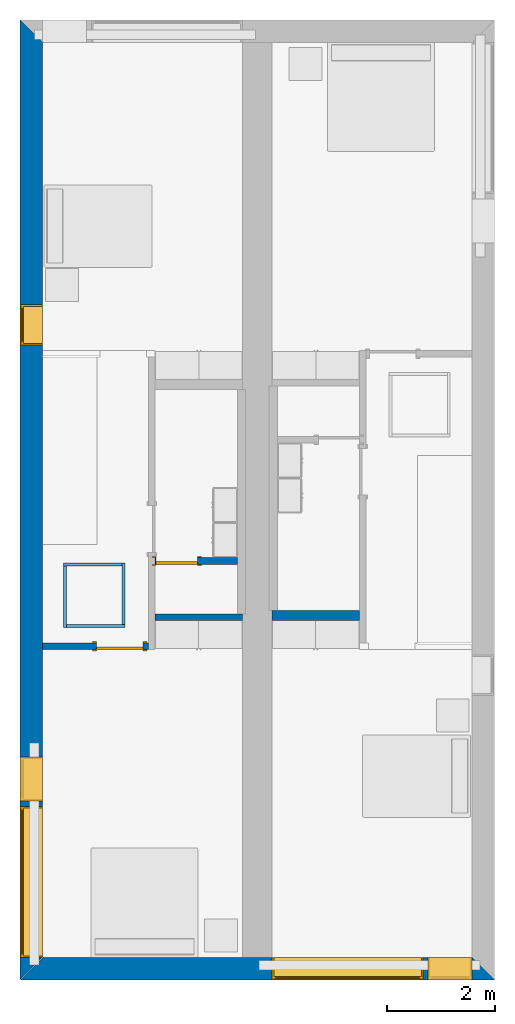
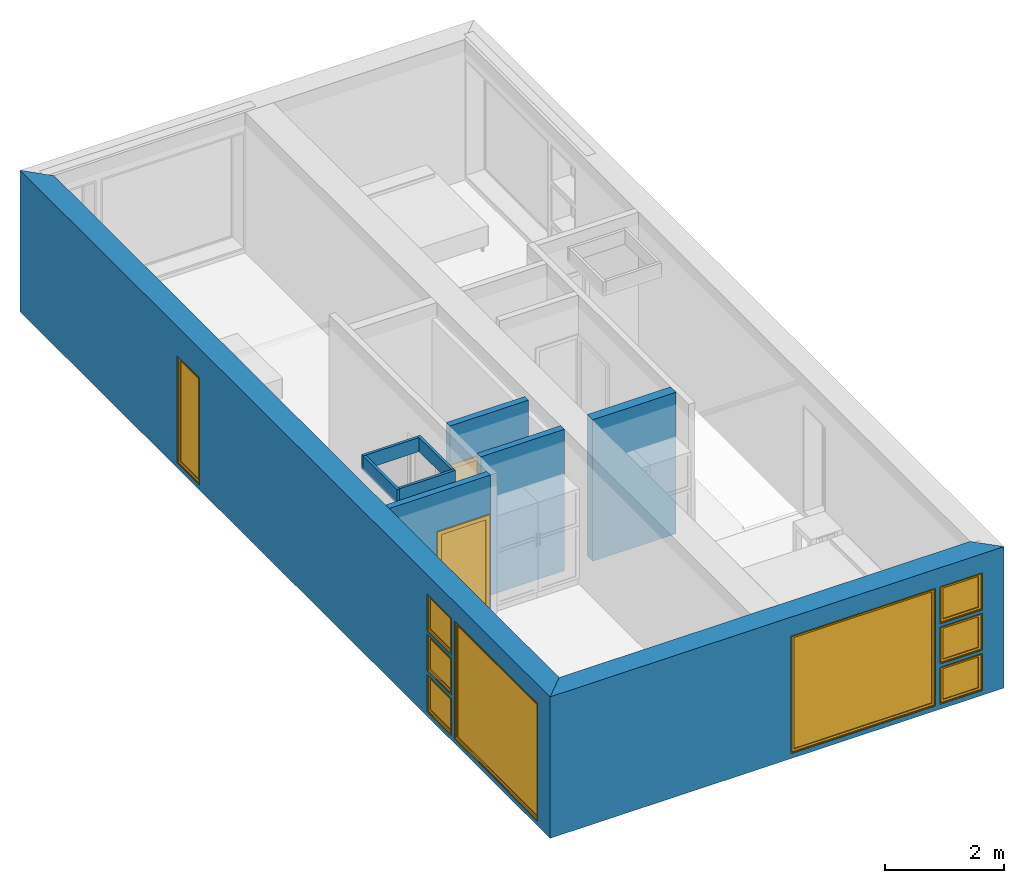
# One storey, part 2 of 16: 10 walls, 9 windows, 2 doors, 11 openings.
"""IFC2X3 building model written with IfcOpenShell, lengths in metres."""

import ifcopenshell
import ifcopenshell.guid

model = None  # the IFC model being written
_history = None  # IfcOwnerHistory: only IFC2X3 demands one
_inside = {}  # id of a spatial element -> (the spatial element, [elements in it])
_under = {}  # id of a project, library or spatial element -> (it, [spatial elements below it])
_declared = {}  # id of a project -> (the project, [libraries it declares])
_typed = {}  # id of a type object -> (the type object, [elements of that type])
_made_of = {}  # id of a material, layer set ... -> (it, [elements and type objects made of it])


def new_model(schema):
    """Start an empty IFC model of exactly this schema.

    Asked for "IFC4X3", IfcOpenShell would pick the latest addendum, in which some entities
    have other attributes; the version numbers below select the first issue.
    IFC2X3 requires an IfcOwnerHistory on every rooted entity: one is made here for all.
    """
    global model, _history
    if schema == "IFC4X3":
        model = ifcopenshell.file(schema_version=(4, 3, 0, 0))
    else:
        model = ifcopenshell.file(schema=schema)
    _inside.clear()
    _under.clear()
    _declared.clear()
    _typed.clear()
    _made_of.clear()
    _history = None
    if model.schema == "IFC2X3":
        org = make("IfcOrganization", Name="unknown")
        user = make(
            "IfcPersonAndOrganization",
            ThePerson=make("IfcPerson", FamilyName="unknown"),
            TheOrganization=org,
        )
        app = make(
            "IfcApplication",
            ApplicationDeveloper=org,
            Version="unknown",
            ApplicationFullName="unknown",
            ApplicationIdentifier="unknown",
        )
        _history = make(
            "IfcOwnerHistory",
            OwningUser=user,
            OwningApplication=app,
            ChangeAction="ADDED",
            CreationDate=0,
        )
    return model


def make(cls, **values):
    """One entity of the class cls with the attributes given. An attribute that is None is left unset."""
    return model.create_entity(
        cls, **{name: value for name, value in values.items() if value is not None}
    )


def entity(cls, *values):
    """Any entity or typed value of the class cls, its attributes in the order of the schema. None: left unset."""
    e = model.create_entity(cls)
    for i, value in enumerate(values):
        if value is not None:
            e[i] = value
    return e


def rooted(cls, **values):
    """An entity with a GlobalId (a new one), such as an element, a storey or a relation."""
    return make(cls, GlobalId=ifcopenshell.guid.new(), OwnerHistory=_history, **values)


def si_unit(unit_type, name, prefix=None):
    """IfcSIUnit, for example si_unit("LENGTHUNIT", "METRE", prefix="MILLI")."""
    return make("IfcSIUnit", UnitType=unit_type, Prefix=prefix, Name=name)


def converted_unit(unit_type, name, factor, base, dimensions=None, offset=None):
    """IfcConversionBasedUnit, such as the inch: factor (a typed value) times the base unit."""
    return make(
        "IfcConversionBasedUnit"
        if offset is None
        else "IfcConversionBasedUnitWithOffset",
        ConversionOffset=offset,
        Dimensions=None
        if dimensions is None
        else entity("IfcDimensionalExponents", *dimensions),
        UnitType=unit_type,
        Name=name,
        ConversionFactor=make(
            "IfcMeasureWithUnit", ValueComponent=factor, UnitComponent=base
        ),
    )


def assignment(units):
    """IfcUnitAssignment: the units of a project."""
    return None if units is None else make("IfcUnitAssignment", Units=units)


def point(xyz):
    """IfcCartesianPoint."""
    return None if xyz is None else make("IfcCartesianPoint", Coordinates=xyz)


def direction(xyz):
    """IfcDirection."""
    return None if xyz is None else make("IfcDirection", DirectionRatios=xyz)


def frame(location, z_axis=None, x_axis=None):
    """IfcAxis2Placement3D, a coordinate frame: its origin and axes. An axis left out is left unset."""
    return make(
        "IfcAxis2Placement3D",
        Location=point(location),
        Axis=direction(z_axis),
        RefDirection=direction(x_axis),
    )


def frame_2d(location, x_axis=None):
    """IfcAxis2Placement2D, a coordinate frame in the plane: its origin and x axis."""
    return make(
        "IfcAxis2Placement2D", Location=point(location), RefDirection=direction(x_axis)
    )


def origin():
    """The frame at (0, 0, 0) with its axes left unset."""
    return frame((0.0, 0.0, 0.0))


def origin_2d_with_axis():
    """The frame at (0, 0) in the plane with the x axis (1, 0) written out."""
    return frame_2d((0.0, 0.0), x_axis=(1.0, 0.0))


def place(relative_to, where):
    """IfcLocalPlacement: puts the frame where relative to a parent placement (None: the world)."""
    return make(
        "IfcLocalPlacement", PlacementRelTo=relative_to, RelativePlacement=where
    )


def context(
    kind, dimensions, precision=None, world=None, true_north=None, identifier=None
):
    """IfcGeometricRepresentationContext, for example the 3D "Model" context."""
    return make(
        "IfcGeometricRepresentationContext",
        ContextIdentifier=identifier,
        ContextType=kind,
        CoordinateSpaceDimension=dimensions,
        Precision=precision,
        WorldCoordinateSystem=world,
        TrueNorth=true_north,
    )


def project(units=None, contexts=None):
    """IfcProject with its units and contexts."""
    return rooted(
        "IfcProject",
        Name="project",
        RepresentationContexts=contexts,
        UnitsInContext=assignment(units),
    )


def spatial(cls, under=None, at=None, **own):
    """A site, building, storey or space (cls), placed at a placement, below another one or the project."""
    s = rooted(cls, ObjectPlacement=at, **own)
    if under is not None:
        _under.setdefault(under.id(), (under, []))[1].append(s)
    return s


def polyline(points):
    """IfcPolyline through the points."""
    return make("IfcPolyline", Points=[point(p) for p in points])


def profile(cls, at=None, kind="AREA", **sizes):
    """A parametric profile (cls). Its sizes go by their IFC names, for example OverallWidth=200.0."""
    return make(cls, ProfileType=kind, Position=at, **sizes)


def rectangle(**sizes):
    """IfcRectangleProfileDef."""
    return profile("IfcRectangleProfileDef", **sizes)


def outline(outer, holes=None, kind="AREA"):
    """IfcArbitraryClosedProfileDef: a profile drawn as a closed curve; with holes, ...WithVoids."""
    if holes is None:
        return make("IfcArbitraryClosedProfileDef", ProfileType=kind, OuterCurve=outer)
    return make(
        "IfcArbitraryProfileDefWithVoids",
        ProfileType=kind,
        OuterCurve=outer,
        InnerCurves=holes,
    )


def extrude(swept, where, along, depth):
    """IfcExtrudedAreaSolid: the profile swept, set in the frame where, extruded along a direction by depth."""
    return make(
        "IfcExtrudedAreaSolid",
        SweptArea=swept,
        Position=where,
        ExtrudedDirection=direction(along),
        Depth=depth,
    )


def shape(context_of_items, identifier, shape_type, items):
    """IfcShapeRepresentation: the items that make up one representation, for example the "Body"."""
    return make(
        "IfcShapeRepresentation",
        ContextOfItems=context_of_items,
        RepresentationIdentifier=identifier,
        RepresentationType=shape_type,
        Items=items,
    )


def source(mapping_origin, context_of_items, identifier, shape_type, items):
    """IfcRepresentationMap: a shape defined once, which mapped items show again and again."""
    return make(
        "IfcRepresentationMap",
        MappingOrigin=mapping_origin,
        MappedRepresentation=shape(context_of_items, identifier, shape_type, items),
    )


def transform(
    local_origin,
    x_axis=None,
    y_axis=None,
    z_axis=None,
    scale=None,
    scale2=None,
    scale3=None,
    uniform=True,
):
    """IfcCartesianTransformationOperator3D, or its non-uniform kind. x_axis, y_axis, z_axis: its Axis1, 2, 3."""
    if uniform:
        return make(
            "IfcCartesianTransformationOperator3D",
            Axis1=direction(x_axis),
            Axis2=direction(y_axis),
            LocalOrigin=point(local_origin),
            Scale=scale,
            Axis3=direction(z_axis),
        )
    return make(
        "IfcCartesianTransformationOperator3DnonUniform",
        Axis1=direction(x_axis),
        Axis2=direction(y_axis),
        LocalOrigin=point(local_origin),
        Scale=scale,
        Axis3=direction(z_axis),
        Scale2=scale2,
        Scale3=scale3,
    )


def mapped(mapping_source, mapping_target):
    """IfcMappedItem: shows the shape of a source again, moved by a transform."""
    return make(
        "IfcMappedItem", MappingSource=mapping_source, MappingTarget=mapping_target
    )


def material(Name=None, Category=None):
    """IfcMaterial."""
    return make("IfcMaterial", Name=Name, Category=Category)


def layer(
    of_material, thickness, ventilated=None, Name=None, Category=None, Priority=None
):
    """IfcMaterialLayer: one layer of a wall or slab, of a material (None: an air gap)."""
    return make(
        "IfcMaterialLayer",
        Material=of_material,
        LayerThickness=thickness,
        IsVentilated=ventilated,
        Name=Name,
        Category=Category,
        Priority=Priority,
    )


def layer_set(layers, Name=None):
    """IfcMaterialLayerSet."""
    return make("IfcMaterialLayerSet", MaterialLayers=layers, LayerSetName=Name)


def layer_usage(for_layer_set, set_direction, sense, offset, extent=None):
    """IfcMaterialLayerSetUsage: how a layer set lies in its element."""
    return make(
        "IfcMaterialLayerSetUsage",
        ForLayerSet=for_layer_set,
        LayerSetDirection=set_direction,
        DirectionSense=sense,
        OffsetFromReferenceLine=offset,
        ReferenceExtent=extent,
    )


def made_of(thing, what):
    """Note that an element or type object is made of a material, layer set ...; save() writes the relation."""
    if what is not None:
        _made_of.setdefault(what.id(), (what, []))[1].append(thing)
    return thing


def type_object(cls, material=None, **own):
    """A type object (cls), such as IfcWallType, which elements share."""
    return made_of(rooted(cls, **own), material)


def type_shapes(of_type, sources):
    """Give a type object the sources (RepresentationMaps) that its elements show as mapped items."""
    of_type.RepresentationMaps = sources


def element(
    cls,
    number,
    at=None,
    inside=None,
    cuts=None,
    type_object=None,
    material=None,
    context=None,
    identifier="Body",
    shape_type=None,
    held_by="IfcProductDefinitionShape",
    body=None,
    shapes=None,
    **own,
):
    """One element of the class cls, such as IfcWall. Its Tag is "e" and its number.

    at: its placement. inside: the storey or other place that contains it. cuts: it is an
    opening in that element (IfcRelVoidsElement). A single representation is given by context,
    identifier, shape_type and body (its items); several are given by shapes. held_by: the class
    of the entity that holds the representations. save() writes the other relations.
    """
    e = rooted(cls, Tag="e%d" % number, ObjectPlacement=at, **own)
    if body is not None:
        shapes = [shape(context, identifier, shape_type, body)]
    if shapes is not None:
        e.Representation = make(held_by, Representations=shapes)
    if inside is not None:
        _inside.setdefault(inside.id(), (inside, []))[1].append(e)
    if cuts is not None:
        rooted(
            "IfcRelVoidsElement", RelatingBuildingElement=cuts, RelatedOpeningElement=e
        )
    if type_object is not None:
        _typed.setdefault(type_object.id(), (type_object, []))[1].append(e)
    return made_of(e, material)


def fill(opening, filler):
    """IfcRelFillsElement: the door or window that sits in an opening."""
    return rooted(
        "IfcRelFillsElement",
        RelatingOpeningElement=opening,
        RelatedBuildingElement=filler,
    )


def aggregate(whole, parts):
    """IfcRelAggregates: a whole, such as a stair, and the parts it consists of."""
    return rooted("IfcRelAggregates", RelatingObject=whole, RelatedObjects=parts)


def save(model, path):
    """Write the relations noted so far, then the file.

    IfcRelAggregates (storeys below a building ...), IfcRelContainedInSpatialStructure (elements
    in a storey), IfcRelDefinesByType, IfcRelAssociatesMaterial and IfcRelDeclares: one each for
    every whole, place, type object, material and project.
    """
    for whole, parts in _under.values():
        aggregate(whole, parts)
    for where, things in _inside.values():
        rooted(
            "IfcRelContainedInSpatialStructure",
            RelatedElements=things,
            RelatingStructure=where,
        )
    for kind, things in _typed.values():
        rooted("IfcRelDefinesByType", RelatedObjects=things, RelatingType=kind)
    for what, things in _made_of.values():
        rooted("IfcRelAssociatesMaterial", RelatedObjects=things, RelatingMaterial=what)
    for by, libraries in _declared.values():
        rooted("IfcRelDeclares", RelatingContext=by, RelatedDefinitions=libraries)
    model.write(path)


model = new_model("IFC2X3")

# Units and contexts
model_context = context("Model", 3, precision=1e-09, world=origin())
plan_context = context("Plan", 3, precision=1e-09, world=origin())
ifc_project = project(units=[si_unit("LENGTHUNIT", "METRE"), si_unit("AREAUNIT", "SQUARE_METRE"), si_unit("VOLUMEUNIT", "CUBIC_METRE"), converted_unit("PLANEANGLEUNIT", "DEGREE", entity("IfcRatioMeasure", 0.01745329251994328), si_unit("PLANEANGLEUNIT", "RADIAN"), dimensions=[0, 0, 0, 0, 0, 0, 0]), si_unit("TIMEUNIT", "SECOND")], contexts=[model_context, plan_context])

# Site, building, storey
site_placement = place(None, origin())
site = spatial("IfcSite", under=ifc_project, at=site_placement, CompositionType="ELEMENT")
building_placement = place(site_placement, origin())
building = spatial("IfcBuilding", under=site, at=building_placement, CompositionType="ELEMENT")
storey_placement = place(building_placement, frame((0.0, 0.0, 3.100000000000378)))
storey = spatial("IfcBuildingStorey", under=building, at=storey_placement, Name="Level 2", CompositionType="ELEMENT", Elevation=3.100000000000378)

# Wall, openings, windows
ifc_material_1 = material(Name="Masonry - Brick")
ifc_layer_1 = layer(ifc_material_1, 0.092)
ifc_material_2 = material(Name="Misc. Air Layers - Air Space")
ifc_layer_2 = layer(ifc_material_2, 0.025)
ifc_material_3 = material(Name="Insulation / Thermal Barriers - Rigid insulation")
ifc_layer_3 = layer(ifc_material_3, 0.05)
ifc_material_4 = material(Name="Masonry - Concrete Block")
ifc_layer_4 = layer(ifc_material_4, 0.193)
ifc_material_5 = material(Name="Metal - Stud Layer")
ifc_layer_5 = layer(ifc_material_5, 0.041)
ifc_material_6 = material(Name="Plasterboard")
ifc_layer_6 = layer(ifc_material_6, 0.016)
ifc_layer_set_1 = layer_set([ifc_layer_1, ifc_layer_2, ifc_layer_3, ifc_layer_4, ifc_layer_5, ifc_layer_6], Name="Basic Wall:Exterior - Brick on Block")
ifc_layer_usage_1 = layer_usage(ifc_layer_set_1, "AXIS2", "NEGATIVE", 0.2085000000000001)
wall_1_placement = place(storey_placement, frame((8.799999999999974, -17.5915, 0.0), z_axis=(0.0, 0.0, 1.0), x_axis=(-1.0, 0.0, 0.0)))
wall_1 = element("IfcWallStandardCase", 1, at=wall_1_placement, inside=storey, material=ifc_layer_usage_1, Name="Basic Wall:Exterior - Brick on Block", ObjectType="Basic Wall:Exterior - Brick on Block", context=model_context, shape_type="SweptSolid", body=[
    extrude(outline(polyline([(8.382999999999974, -0.2084999999999994), (8.799999999999974, 0.2085000000000002), (0.0, 0.2085000000000002), (0.4170000000000034, -0.2085000000000011), (4.125000000000003, -0.2085000000000001), (4.675000000000003, -0.2085000000000005), (8.382999999999974, -0.2084999999999994)])), origin(), (0.0, 0.0, 1.0), 2.900000000000012),
])
opening_1_placement = place(wall_1_placement, frame((1.325000000000001, -0.2084999999999981, 0.09999999999982295)))
opening_1 = element("IfcOpeningElement", 2, at=opening_1_placement, cuts=wall_1, ObjectType="Opening", context=model_context, shape_type="SweptSolid", body=[
    extrude(rectangle(XDim=2.409999999999996, YDim=2.8, at=frame_2d((1.204999999999998, 1.4), x_axis=(1.0, 0.0))), frame((0.0, 0.0, 0.0), z_axis=(0.0, 1.0, 0.0), x_axis=(0.0, 0.0, 1.0)), (0.0, 0.0, 1.0), 0.4170000000000001),
])
opening_2_placement = place(wall_1_placement, frame((0.4170000000000005, -0.2084999999999993, 0.0999999999998235)))
opening_2 = element("IfcOpeningElement", 3, at=opening_2_placement, cuts=wall_1, ObjectType="Opening", context=model_context, shape_type="SweptSolid", body=[
    extrude(rectangle(XDim=0.7589999999999981, YDim=0.8189999999999995, at=frame_2d((0.379499999999999, 0.4095000000000003), x_axis=(1.0, 0.0))), frame((0.0, 0.0, 0.0), z_axis=(0.0, 1.0, 0.0), x_axis=(0.0, 0.0, 1.0)), (0.0, 0.0, 1.0), 0.4170000000000001),
])
opening_3_placement = place(wall_1_placement, frame((0.4170000000000168, -0.2084999999999998, 0.9254999999998184)))
opening_3 = element("IfcOpeningElement", 4, at=opening_3_placement, cuts=wall_1, ObjectType="Opening", context=model_context, shape_type="SweptSolid", body=[
    extrude(rectangle(XDim=0.7590000000000007, YDim=0.8189999999999998, at=frame_2d((0.3795000000000003, 0.4094999999999999), x_axis=(-1.0, 0.0))), frame((0.0, 0.0, 0.0), z_axis=(0.0, 1.0, 0.0), x_axis=(0.0, 0.0, 1.0)), (0.0, 0.0, 1.0), 0.4170000000000001),
])
opening_4_placement = place(wall_1_placement, frame((0.4170000000000005, -0.2084999999999993, 1.750999999999819)))
opening_4 = element("IfcOpeningElement", 5, at=opening_4_placement, cuts=wall_1, ObjectType="Opening", context=model_context, shape_type="SweptSolid", body=[
    extrude(rectangle(XDim=0.7589999999999981, YDim=0.8189999999999995, at=frame_2d((0.379499999999999, 0.4095000000000003), x_axis=(1.0, 0.0))), frame((0.0, 0.0, 0.0), z_axis=(0.0, 1.0, 0.0), x_axis=(0.0, 0.0, 1.0)), (0.0, 0.0, 1.0), 0.4170000000000001),
])
window_style_1 = type_object("IfcWindowStyle", Name="2800mm x 2410mm", ConstructionType="NOTDEFINED", OperationType="NOTDEFINED", ParameterTakesPrecedence=False, Sizeable=False)
shared_shape_1 = source(origin(), model_context, "Body", "SweptSolid", [
    extrude(rectangle(XDim=0.01199999999999998, YDim=2.673999999999997, at=origin_2d_with_axis()), frame((1.400000000000007, 0.3759999999999956, 0.06299999999998514), z_axis=(0.0, 0.0, 1.0), x_axis=(0.0, -1.0, 0.0)), (0.0, 0.0, 1.0), 2.284000000000005),
    extrude(outline(polyline([(-1.381, -1.186000000000001), (1.381, -1.186000000000001), (1.381, 1.186000000000001), (-1.381, 1.186000000000001), (-1.381, -1.186000000000001)]), holes=[polyline([(-1.336999999999999, -1.142000000000002), (-1.336999999999999, 1.142000000000003), (1.336999999999997, 1.142000000000003), (1.336999999999997, -1.142000000000002), (-1.336999999999999, -1.142000000000002)])]), frame((1.400000000000008, 0.3539999999999681, 1.204999999999988), z_axis=(0.0, 1.0, 0.0), x_axis=(1.0, 0.0, 0.0)), (0.0, 0.0, 1.0), 0.04400000000002743),
    extrude(outline(polyline([(-1.4, -1.204999999999996), (1.4, -1.204999999999996), (1.4, 1.204999999999996), (-1.4, 1.204999999999996), (-1.4, -1.204999999999996)]), holes=[polyline([(-1.381000000000001, -1.185999999999981), (-1.381000000000001, 1.186000000000022), (1.380999999999999, 1.186000000000022), (1.380999999999999, -1.185999999999981), (-1.381000000000001, -1.185999999999981)])]), frame((1.400000000000009, 0.3539999999999681, 1.205000000000009), z_axis=(0.0, 1.0, 0.0), x_axis=(1.0, 0.0, 0.0)), (0.0, 0.0, 1.0), 0.06300000000002744),
    extrude(outline(polyline([(-1.4, -1.204999999999995), (1.4, -1.204999999999995), (1.4, 1.204999999999995), (-1.4, 1.204999999999995), (-1.4, -1.204999999999995)]), holes=[polyline([(-1.368, -1.172999999999982), (-1.368, 1.17300000000002), (1.368, 1.17300000000002), (1.367999999999999, -1.172999999999982), (-1.368, -1.172999999999982)])]), frame((1.40000000000001, 0.0, 1.205000000000008), z_axis=(0.0, 1.0, 0.0), x_axis=(1.0, 0.0, 0.0)), (0.0, 0.0, 1.0), 0.3539999999999727),
])
type_shapes(window_style_1, [shared_shape_1])
window_1_placement = place(opening_1_placement, origin())
window_1 = element("IfcWindow", 6, at=window_1_placement, inside=storey, type_object=window_style_1, ObjectType="2800mm x 2410mm", OverallHeight=2.409999999999996, OverallWidth=2.8, context=model_context, shape_type="MappedRepresentation", body=[
    mapped(shared_shape_1, transform((0.0, 0.0, 0.0), scale=1.0)),
])
fill(opening_1, window_1)
window_style_2 = type_object("IfcWindowStyle", Name="819mm x 759mm", ConstructionType="NOTDEFINED", OperationType="NOTDEFINED", ParameterTakesPrecedence=False, Sizeable=False)
shared_shape_2 = source(origin(), model_context, "Body", "SweptSolid", [
    extrude(rectangle(XDim=0.01199999999999998, YDim=0.6929999999999971, at=origin_2d_with_axis()), frame((0.4095000000000068, 0.3759999999999988, 0.06299999999998514), z_axis=(0.0, 0.0, 1.0), x_axis=(0.0, -1.0, 0.0)), (0.0, 0.0, 1.0), 0.6330000000000073),
    extrude(outline(polyline([(-0.3904999999999999, -0.3605000000000028), (0.3904999999999999, -0.3605000000000028), (0.3904999999999999, 0.3605000000000027), (-0.3904999999999999, 0.3605000000000027), (-0.3904999999999999, -0.3605000000000028)]), holes=[polyline([(-0.3464999999999996, -0.3165000000000033), (-0.3464999999999996, 0.316500000000004), (0.3464999999999974, 0.316500000000004), (0.3464999999999974, -0.3165000000000033), (-0.3464999999999996, -0.3165000000000033)])]), frame((0.4095000000000078, 0.3539999999999714, 0.3794999999999891), z_axis=(0.0, 1.0, 0.0), x_axis=(1.0, 0.0, 0.0)), (0.0, 0.0, 1.0), 0.04400000000002743),
    extrude(outline(polyline([(-0.4094999999999998, -0.3794999999999972), (0.4094999999999998, -0.3794999999999972), (0.4094999999999998, 0.3794999999999971), (-0.4094999999999998, 0.3794999999999971), (-0.4094999999999998, -0.3794999999999972)]), holes=[polyline([(-0.3905000000000011, -0.3604999999999823), (-0.3905000000000012, 0.3605000000000231), (0.3904999999999986, 0.3605000000000231), (0.3904999999999987, -0.3604999999999823), (-0.3905000000000011, -0.3604999999999823)])]), frame((0.4095000000000091, 0.3539999999999714, 0.3795000000000096), z_axis=(0.0, 1.0, 0.0), x_axis=(1.0, 0.0, 0.0)), (0.0, 0.0, 1.0), 0.06300000000002744),
    extrude(outline(polyline([(-0.4095000000000002, -0.3794999999999967), (0.4095000000000002, -0.3794999999999967), (0.4095000000000002, 0.3794999999999966), (-0.4095000000000002, 0.3794999999999966), (-0.4095000000000002, -0.3794999999999967)]), holes=[polyline([(-0.3774999999999999, -0.3474999999999832), (-0.3774999999999999, 0.3475000000000212), (0.3775000000000001, 0.3475000000000212), (0.3775000000000001, -0.3474999999999832), (-0.3774999999999999, -0.3474999999999832)])]), frame((0.4095000000000096, 0.0, 0.379500000000009), z_axis=(0.0, 1.0, 0.0), x_axis=(1.0, 0.0, 0.0)), (0.0, 0.0, 1.0), 0.3539999999999727),
])
type_shapes(window_style_2, [shared_shape_2])
window_2_placement = place(opening_2_placement, origin())
window_2 = element("IfcWindow", 7, at=window_2_placement, inside=storey, type_object=window_style_2, ObjectType="819mm x 759mm", OverallHeight=0.758999999999998, OverallWidth=0.8190000000000001, context=model_context, shape_type="MappedRepresentation", body=[
    mapped(shared_shape_2, transform((0.0, 0.0, 0.0), scale=1.0)),
])
fill(opening_2, window_2)
window_3_placement = place(opening_4_placement, origin())
window_3 = element("IfcWindow", 8, at=window_3_placement, inside=storey, type_object=window_style_2, ObjectType="819mm x 759mm", OverallHeight=0.758999999999998, OverallWidth=0.8190000000000001, context=model_context, shape_type="MappedRepresentation", body=[
    mapped(shared_shape_2, transform((0.0, 0.0, 0.0), scale=1.0)),
])
fill(opening_4, window_3)
window_style_3 = type_object("IfcWindowStyle", Name="819mm x 759mm", ConstructionType="NOTDEFINED", OperationType="NOTDEFINED", ParameterTakesPrecedence=False, Sizeable=False)
shared_shape_3 = source(origin(), model_context, "Body", "SweptSolid", [
    extrude(rectangle(XDim=0.01269999999999999, YDim=0.6919999999999978, at=origin_2d_with_axis()), frame((0.4095000000000003, 0.3757750000000001, 0.06350000000000397), z_axis=(0.0, 0.0, 1.0), x_axis=(0.0, 1.0, 0.0)), (0.0, 0.0, 1.0), 0.6320000000000041),
    extrude(outline(polyline([(-0.3904499999999989, -0.3604500000000012), (0.3904499999999989, -0.3604500000000012), (0.3904499999999989, 0.3604500000000012), (-0.3904499999999989, 0.3604500000000012), (-0.3904499999999989, -0.3604500000000012)]), holes=[polyline([(-0.3459999999999978, -0.3160000000000016), (-0.3459999999999978, 0.3160000000000026), (0.346, 0.3160000000000026), (0.346, -0.3160000000000016), (-0.3459999999999978, -0.3160000000000016)])]), frame((0.4094999999999992, 0.3535500000000001, 0.3795000000000066), z_axis=(0.0, 1.0, 0.0), x_axis=(1.0, 0.0, 0.0)), (0.0, 0.0, 1.0), 0.04445),
    extrude(outline(polyline([(-0.4094999999999992, -0.3795000000000012), (0.4094999999999992, -0.3795000000000012), (0.4094999999999992, 0.3795000000000012), (-0.4094999999999992, 0.3795000000000012), (-0.4094999999999992, -0.3795000000000012)]), holes=[polyline([(-0.3777500000000001, -0.3477499999999997), (-0.3777500000000001, 0.3477500000000008), (0.3777499999999982, 0.3477500000000008), (0.3777499999999982, -0.3477499999999997), (-0.3777500000000001, -0.3477499999999997)])]), frame((0.4095000000000007, 0.0, 0.3795000000000077), z_axis=(0.0, 1.0, 0.0), x_axis=(1.0, 0.0, 0.0)), (0.0, 0.0, 1.0), 0.3535500000000001),
    extrude(outline(polyline([(-0.3795000000000017, -0.4094999999999995), (0.3795000000000017, -0.4094999999999995), (0.3795000000000017, 0.4094999999999995), (-0.3795000000000017, 0.4094999999999995), (-0.3795000000000017, -0.4094999999999995)]), holes=[polyline([(-0.3604500000000023, -0.3904499999999987), (-0.3604500000000023, 0.3904499999999997), (0.3604500000000017, 0.3904499999999997), (0.3604500000000017, -0.3904499999999988), (-0.3604500000000023, -0.3904499999999987)])]), frame((0.4095000000000004, 0.3535500000000001, 0.3795000000000071), z_axis=(0.0, 1.0, 0.0), x_axis=(0.0, 0.0, -1.0)), (0.0, 0.0, 1.0), 0.06345),
])
type_shapes(window_style_3, [shared_shape_3])
window_4_placement = place(opening_3_placement, origin())
window_4 = element("IfcWindow", 9, at=window_4_placement, inside=storey, type_object=window_style_3, ObjectType="819mm x 759mm", OverallHeight=0.7590000000000007, OverallWidth=0.8190000000000001, context=model_context, shape_type="MappedRepresentation", body=[
    mapped(shared_shape_3, transform((0.0, 0.0, 0.0), scale=1.0)),
])
fill(opening_3, window_4)

ifc_layer_usage_2 = layer_usage(ifc_layer_set_1, "AXIS2", "NEGATIVE", 0.2085000000000001)
wall_2_placement = place(storey_placement, frame((0.208499999999999, -17.79999999999997, 0.0), z_axis=(0.0, 0.0, 1.0), x_axis=(0.0, 1.0, 0.0)))
wall_2 = element("IfcWallStandardCase", 10, at=wall_2_placement, inside=storey, material=ifc_layer_usage_2, Name="Basic Wall:Exterior - Brick on Block", ObjectType="Basic Wall:Exterior - Brick on Block", context=model_context, shape_type="SweptSolid", body=[
    extrude(outline(polyline([(17.38299999999997, -0.2085000000000001), (17.79999999999997, 0.2085000000000001), (0.0, 0.2085000000000001), (0.4170000000000005, -0.2085), (6.125999999999976, -0.2085), (6.249999999999976, -0.2085000000000001), (17.38299999999997, -0.2085000000000001)])), origin(), (0.0, 0.0, 1.0), 2.900000000000013),
])
opening_5_placement = place(wall_2_placement, frame((0.4169999999999983, -0.2084999999999956, 0.09999999999981862)))
opening_5 = element("IfcOpeningElement", 11, at=opening_5_placement, cuts=wall_2, ObjectType="Opening", context=model_context, shape_type="SweptSolid", body=[
    extrude(rectangle(XDim=2.409999999999996, YDim=2.8, at=frame_2d((1.204999999999998, 1.4), x_axis=(1.0, 0.0))), frame((0.0, 0.0, 0.0), z_axis=(0.0, 1.0, 0.0), x_axis=(0.0, 0.0, 1.0)), (0.0, 0.0, 1.0), 0.4170000000000001),
])
opening_6_placement = place(wall_2_placement, frame((3.317, -0.208499999999999, 1.750999999999819)))
opening_6 = element("IfcOpeningElement", 12, at=opening_6_placement, cuts=wall_2, ObjectType="Opening", context=model_context, shape_type="SweptSolid", body=[
    extrude(rectangle(XDim=0.7589999999999981, YDim=0.8189999999999995, at=frame_2d((0.379499999999999, 0.4095000000000003), x_axis=(1.0, 0.0))), frame((0.0, 0.0, 0.0), z_axis=(0.0, 1.0, 0.0), x_axis=(0.0, 0.0, 1.0)), (0.0, 0.0, 1.0), 0.4170000000000001),
])
opening_7_placement = place(wall_2_placement, frame((3.317, -0.208499999999999, 0.09999999999981862)))
opening_7 = element("IfcOpeningElement", 13, at=opening_7_placement, cuts=wall_2, ObjectType="Opening", context=model_context, shape_type="SweptSolid", body=[
    extrude(rectangle(XDim=0.7589999999999981, YDim=0.8189999999999995, at=frame_2d((0.3794999999999993, 0.4095000000000003), x_axis=(1.0, 0.0))), frame((0.0, 0.0, 0.0), z_axis=(0.0, 1.0, 0.0), x_axis=(0.0, 0.0, 1.0)), (0.0, 0.0, 1.0), 0.4170000000000001),
])
opening_8_placement = place(wall_2_placement, frame((3.317000000000015, -0.2085000000000003, 0.9254999999998184)))
opening_8 = element("IfcOpeningElement", 14, at=opening_8_placement, cuts=wall_2, ObjectType="Opening", context=model_context, shape_type="SweptSolid", body=[
    extrude(rectangle(XDim=0.7590000000000007, YDim=0.8189999999999998, at=frame_2d((0.3795000000000003, 0.4094999999999999), x_axis=(-1.0, 0.0))), frame((0.0, 0.0, 0.0), z_axis=(0.0, 1.0, 0.0), x_axis=(0.0, 0.0, 1.0)), (0.0, 0.0, 1.0), 0.4170000000000001),
])
opening_9_placement = place(wall_2_placement, frame((11.77399999999997, -0.2084999999999996, 0.09999999999981862)))
opening_9 = element("IfcOpeningElement", 15, at=opening_9_placement, cuts=wall_2, ObjectType="Opening", context=model_context, shape_type="SweptSolid", body=[
    extrude(rectangle(XDim=2.199999999999996, YDim=0.7499999999999996, at=frame_2d((1.099999999999999, 0.3749999999999987), x_axis=(1.0, 0.0))), frame((0.0, 0.0, 0.0), z_axis=(0.0, 1.0, 0.0), x_axis=(0.0, 0.0, 1.0)), (0.0, 0.0, 1.0), 0.4170000000000001),
])
window_style_4 = type_object("IfcWindowStyle", Name="750mm x 2200mm", ConstructionType="NOTDEFINED", OperationType="NOTDEFINED", ParameterTakesPrecedence=False, Sizeable=False)
shared_shape_4 = source(origin(), model_context, "Body", "SweptSolid", [
    extrude(rectangle(XDim=0.01199999999999998, YDim=0.623999999999997, at=origin_2d_with_axis()), frame((0.375000000000007, 0.3759999999999988, 0.06299999999998514), z_axis=(0.0, 0.0, 1.0), x_axis=(0.0, -1.0, 0.0)), (0.0, 0.0, 1.0), 2.074000000000006),
    extrude(outline(polyline([(-0.3559999999999999, -1.081000000000002), (0.3559999999999999, -1.081000000000002), (0.3559999999999999, 1.081000000000002), (-0.3559999999999999, 1.081000000000002), (-0.3559999999999999, -1.081000000000002)]), holes=[polyline([(-0.3119999999999996, -1.037000000000002), (-0.3119999999999996, 1.037000000000003), (0.3119999999999975, 1.037000000000003), (0.3119999999999975, -1.037000000000002), (-0.3119999999999996, -1.037000000000002)])]), frame((0.3750000000000081, 0.3539999999999715, 1.099999999999989), z_axis=(0.0, 1.0, 0.0), x_axis=(1.0, 0.0, 0.0)), (0.0, 0.0, 1.0), 0.04400000000002743),
    extrude(outline(polyline([(-0.3749999999999997, -1.099999999999996), (0.3749999999999997, -1.099999999999996), (0.3749999999999997, 1.099999999999996), (-0.3749999999999997, 1.099999999999996), (-0.3749999999999997, -1.099999999999996)]), holes=[polyline([(-0.3560000000000012, -1.080999999999981), (-0.3560000000000013, 1.081000000000022), (0.3559999999999985, 1.081000000000022), (0.3559999999999986, -1.080999999999981), (-0.3560000000000012, -1.080999999999981)])]), frame((0.3750000000000094, 0.3539999999999715, 1.100000000000009), z_axis=(0.0, 1.0, 0.0), x_axis=(1.0, 0.0, 0.0)), (0.0, 0.0, 1.0), 0.06300000000002744),
    extrude(outline(polyline([(-0.3750000000000001, -1.099999999999996), (0.3750000000000001, -1.099999999999996), (0.3750000000000001, 1.099999999999996), (-0.3750000000000001, 1.099999999999996), (-0.3750000000000001, -1.099999999999996)]), holes=[polyline([(-0.3429999999999999, -1.067999999999982), (-0.3429999999999999, 1.06800000000002), (0.3430000000000001, 1.06800000000002), (0.3430000000000001, -1.067999999999982), (-0.3429999999999999, -1.067999999999982)])]), frame((0.3750000000000099, 0.0, 1.100000000000008), z_axis=(0.0, 1.0, 0.0), x_axis=(1.0, 0.0, 0.0)), (0.0, 0.0, 1.0), 0.3539999999999727),
])
type_shapes(window_style_4, [shared_shape_4])
window_5_placement = place(opening_9_placement, origin())
window_5 = element("IfcWindow", 16, at=window_5_placement, inside=storey, type_object=window_style_4, ObjectType="750mm x 2200mm", OverallHeight=2.199999999999997, OverallWidth=0.7499999999999996, context=model_context, shape_type="MappedRepresentation", body=[
    mapped(shared_shape_4, transform((0.0, 0.0, 0.0), scale=1.0)),
])
fill(opening_9, window_5)
window_6_placement = place(opening_5_placement, origin())
window_6 = element("IfcWindow", 17, at=window_6_placement, inside=storey, type_object=window_style_1, ObjectType="2800mm x 2410mm", OverallHeight=2.409999999999996, OverallWidth=2.8, context=model_context, shape_type="MappedRepresentation", body=[
    mapped(shared_shape_1, transform((0.0, 0.0, 0.0), scale=1.0)),
])
fill(opening_5, window_6)
window_7_placement = place(opening_6_placement, origin())
window_7 = element("IfcWindow", 18, at=window_7_placement, inside=storey, type_object=window_style_2, ObjectType="819mm x 759mm", OverallHeight=0.758999999999998, OverallWidth=0.8190000000000001, context=model_context, shape_type="MappedRepresentation", body=[
    mapped(shared_shape_2, transform((0.0, 0.0, 0.0), scale=1.0)),
])
fill(opening_6, window_7)
window_8_placement = place(opening_7_placement, origin())
window_8 = element("IfcWindow", 19, at=window_8_placement, inside=storey, type_object=window_style_2, ObjectType="819mm x 759mm", OverallHeight=0.7589999999999986, OverallWidth=0.8190000000000001, context=model_context, shape_type="MappedRepresentation", body=[
    mapped(shared_shape_2, transform((0.0, 0.0, 0.0), scale=1.0)),
])
fill(opening_7, window_8)
window_9_placement = place(opening_8_placement, origin())
window_9 = element("IfcWindow", 20, at=window_9_placement, inside=storey, type_object=window_style_3, ObjectType="819mm x 759mm", OverallHeight=0.7590000000000007, OverallWidth=0.8190000000000001, context=model_context, shape_type="MappedRepresentation", body=[
    mapped(shared_shape_3, transform((0.0, 0.0, 0.0), scale=1.0)),
])
fill(opening_8, window_9)

# Wall, opening, door
ifc_layer_7 = layer(ifc_material_6, 0.016)
ifc_layer_8 = layer(ifc_material_5, 0.092)
ifc_layer_9 = layer(ifc_material_6, 0.016)
ifc_layer_set_2 = layer_set([ifc_layer_7, ifc_layer_8, ifc_layer_9], Name="Basic Wall:Interior - Partition (92mm Stud)")
ifc_layer_usage_3 = layer_usage(ifc_layer_set_2, "AXIS2", "NEGATIVE", 0.062)
wall_3_placement = place(storey_placement, frame((2.381999999999991, -11.612, 0.0), z_axis=(0.0, 0.0, 1.0), x_axis=(-1.0, 0.0, 0.0)))
wall_3 = element("IfcWallStandardCase", 21, at=wall_3_placement, inside=storey, material=ifc_layer_usage_3, Name="Basic Wall:Interior - Partition (92mm Stud)", ObjectType="Basic Wall:Interior - Partition (92mm Stud)", context=model_context, shape_type="SweptSolid", body=[
    extrude(rectangle(XDim=1.964999999999992, YDim=0.1240000000000021, at=frame_2d((0.9824999999999962, 0.0), x_axis=(-1.0, 0.0))), origin(), (0.0, 0.0, 1.0), 2.900000000000012),
])
opening_10_placement = place(wall_3_placement, frame((0.09999999999999892, -0.0620000000000021, 0.0)))
opening_10 = element("IfcOpeningElement", 22, at=opening_10_placement, cuts=wall_3, Name="M_Single-Flush:0864 x 2032mm:0864 x 2032mm:1", ObjectType="Opening", context=model_context, shape_type="SweptSolid", body=[
    extrude(rectangle(XDim=0.8639999999999994, YDim=2.032, at=frame_2d((1.016, 0.4319999999999998), x_axis=(0.0, -1.0))), frame((0.0, 0.0, 0.0), z_axis=(0.0, 1.0, 0.0), x_axis=(0.0, 0.0, 1.0)), (0.0, 0.0, 1.0), 0.124),
])
door_style_1 = type_object("IfcDoorStyle", Name="0864 x 2032mm", ConstructionType="NOTDEFINED", OperationType="SINGLE_SWING_LEFT", ParameterTakesPrecedence=False, Sizeable=False)
shared_shape_5 = source(origin(), model_context, "Body", "SweptSolid", [
    extrude(outline(polyline([(-0.5079999999999999, -1.072999999999999), (0.5079999999999998, -1.072999999999999), (0.5079999999999998, 1.035000000000001), (0.4319999999999997, 1.035000000000001), (0.4319999999999997, -0.9970000000000019), (-0.4319999999999996, -0.9970000000000019), (-0.4319999999999996, 1.035000000000001), (-0.5079999999999999, 1.035000000000001), (-0.5079999999999999, -1.072999999999999)])), frame((0.4320000000000002, 0.1489999999999882, 1.035000000000001), z_axis=(0.0, -1.0, 0.0), x_axis=(-1.0, 0.0, 0.0)), (0.0, 0.0, 1.0), 0.02499999999999444),
    extrude(outline(polyline([(-1.073, -0.5079999999999971), (1.035, -0.5079999999999971), (1.035, -0.4320000000000073), (-0.9969999999999997, -0.4320000000000073), (-0.9969999999999997, 0.4320000000000018), (1.035, 0.4320000000000018), (1.035, 0.5080000000000027), (-1.073, 0.5080000000000027), (-1.073, -0.5079999999999971)])), frame((0.4319999999999979, 0.0, 1.035), z_axis=(0.0, -1.0, 0.0), x_axis=(0.0, 0.0, -1.0)), (0.0, 0.0, 1.0), 0.02500000000000558),
    extrude(rectangle(XDim=0.8639999999999998, YDim=0.051, at=origin_2d_with_axis()), frame((0.4320000000000005, 0.09849999999999375, 0.0)), (0.0, 0.0, 1.0), 2.032),
])
type_shapes(door_style_1, [shared_shape_5])
door_1_placement = place(opening_10_placement, origin())
door_1 = element("IfcDoor", 23, at=door_1_placement, inside=storey, type_object=door_style_1, Name="M_Single-Flush:0864 x 2032mm:0864 x 2032mm", ObjectType="0864 x 2032mm", OverallHeight=2.032, OverallWidth=0.8639999999999995, context=model_context, shape_type="MappedRepresentation", body=[
    mapped(shared_shape_5, transform((0.0, 0.0, 0.0), scale=1.0)),
])
fill(opening_10, door_1)

# Walls
ifc_layer_usage_4 = layer_usage(ifc_layer_set_2, "AXIS2", "NEGATIVE", 0.062)
wall_4_placement = place(storey_placement, frame((4.124999999999983, -11.072, 0.0), z_axis=(0.0, 0.0, 1.0), x_axis=(-1.0, 0.0, 0.0)))
element("IfcWallStandardCase", 24, at=wall_4_placement, inside=storey, material=ifc_layer_usage_4, Name="Basic Wall:Interior - Partition (92mm Stud)", ObjectType="Basic Wall:Interior - Partition (92mm Stud)", context=model_context, shape_type="SweptSolid", body=[
    extrude(rectangle(XDim=1.61899999999999, YDim=0.1240000000000021, at=frame_2d((0.8094999999999952, 0.0), x_axis=(-1.0, 0.0))), origin(), (0.0, 0.0, 1.0), 2.900000000000012),
])
ifc_layer_10 = layer(ifc_material_6, 0.016)
ifc_layer_11 = layer(ifc_material_5, 0.152)
ifc_layer_12 = layer(ifc_material_6, 0.016)
ifc_layer_set_3 = layer_set([ifc_layer_10, ifc_layer_11, ifc_layer_12], Name="Basic Wall:Interior - Plumbing (152mm Stud)")
ifc_layer_usage_5 = layer_usage(ifc_layer_set_3, "AXIS2", "NEGATIVE", 0.092)
wall_5_placement = place(storey_placement, frame((6.294000000000001, -11.04200000000001, 0.0), z_axis=(0.0, 0.0, 1.0), x_axis=(-1.0, 0.0, 0.0)))
element("IfcWallStandardCase", 25, at=wall_5_placement, inside=storey, material=ifc_layer_usage_5, Name="Basic Wall:Interior - Plumbing (152mm Stud)", ObjectType="Basic Wall:Interior - Plumbing (152mm Stud)", context=model_context, shape_type="SweptSolid", body=[
    extrude(rectangle(XDim=1.619000000000018, YDim=0.1840000000000015, at=frame_2d((0.8095000000000092, 0.0), x_axis=(-1.0, 0.0))), origin(), (0.0, 0.0, 1.0), 2.900000000000012),
])

# Wall, opening, door
ifc_layer_usage_6 = layer_usage(ifc_layer_set_2, "AXIS2", "NEGATIVE", 0.062)
wall_6_placement = place(storey_placement, frame((4.029999999999983, -10.03205117851059, 0.0), z_axis=(0.0, 0.0, 1.0), x_axis=(-1.0, 0.0, 0.0)))
wall_6 = element("IfcWallStandardCase", 26, at=wall_6_placement, inside=storey, material=ifc_layer_usage_6, Name="Basic Wall:Interior - Partition (92mm Stud)", ObjectType="Basic Wall:Interior - Partition (92mm Stud)", context=model_context, shape_type="SweptSolid", body=[
    extrude(rectangle(XDim=1.52399999999999, YDim=0.1240000000000021, at=frame_2d((0.7619999999999951, 0.0), x_axis=(-1.0, 0.0))), origin(), (0.0, 0.0, 1.0), 2.900000000000012),
])
opening_11_placement = place(wall_6_placement, frame((0.7419999999999857, -0.0619999999999989, 0.0)))
opening_11 = element("IfcOpeningElement", 27, at=opening_11_placement, cuts=wall_6, Name="M_Single-Flush:0762 x 2032mm:0762 x 2032mm:1", ObjectType="Opening", context=model_context, shape_type="SweptSolid", body=[
    extrude(rectangle(XDim=0.7619999999999997, YDim=2.032, at=frame_2d((1.016, 0.3810000000000001), x_axis=(0.0, 1.0))), frame((0.0, 0.0, 0.0), z_axis=(0.0, 1.0, 0.0), x_axis=(0.0, 0.0, 1.0)), (0.0, 0.0, 1.0), 0.124),
])
door_style_2 = type_object("IfcDoorStyle", Name="0762 x 2032mm", ConstructionType="NOTDEFINED", OperationType="SINGLE_SWING_RIGHT", ParameterTakesPrecedence=False, Sizeable=False)
shared_shape_6 = source(origin(), model_context, "Body", "SweptSolid", [
    extrude(outline(polyline([(-0.457, -1.072999999999999), (0.4569999999999999, -1.072999999999999), (0.4569999999999999, 1.035000000000001), (0.3809999999999998, 1.035000000000001), (0.3809999999999998, -0.9970000000000019), (-0.3809999999999997, -0.9970000000000019), (-0.3809999999999997, 1.035000000000001), (-0.457, 1.035000000000001), (-0.457, -1.072999999999999)])), frame((0.3810000000000009, 0.1239999999999993, 1.035000000000001), z_axis=(0.0, 1.0, 0.0), x_axis=(1.0, 0.0, 0.0)), (0.0, 0.0, 1.0), 0.02499999999999445),
    extrude(outline(polyline([(-1.073, -0.4569999999999971), (1.035, -0.4569999999999971), (1.035, -0.3810000000000074), (-0.9969999999999997, -0.3810000000000074), (-0.9969999999999997, 0.3810000000000018), (1.035, 0.3810000000000018), (1.035, 0.4570000000000027), (-1.073, 0.4570000000000027), (-1.073, -0.4569999999999971)])), frame((0.3810000000000031, -0.02500000000000627, 1.035), z_axis=(0.0, 1.0, 0.0), x_axis=(0.0, 0.0, -1.0)), (0.0, 0.0, 1.0), 0.02500000000000558),
    extrude(rectangle(XDim=0.051, YDim=0.7619999999999998, at=origin_2d_with_axis()), frame((0.3810000000000005, 0.09849999999999928, 0.0), z_axis=(0.0, 0.0, 1.0), x_axis=(0.0, 1.0, 0.0)), (0.0, 0.0, 1.0), 2.032),
])
type_shapes(door_style_2, [shared_shape_6])
door_2_placement = place(opening_11_placement, origin())
door_2 = element("IfcDoor", 28, at=door_2_placement, inside=storey, type_object=door_style_2, Name="M_Single-Flush:0762 x 2032mm:0762 x 2032mm", ObjectType="0762 x 2032mm", OverallHeight=2.032, OverallWidth=0.762, context=model_context, shape_type="MappedRepresentation", body=[
    mapped(shared_shape_6, transform((0.0, 0.0, 0.0), scale=1.0)),
])
fill(opening_11, door_2)

# Walls
ifc_layer_13 = layer(ifc_material_5, 0.038)
ifc_layer_14 = layer(ifc_material_6, 0.016)
ifc_layer_set_4 = layer_set([ifc_layer_13, ifc_layer_14], Name="Basic Wall:Interior - Furring (38 mm Stud)")
ifc_layer_usage_7 = layer_usage(ifc_layer_set_4, "AXIS2", "NEGATIVE", 0.027)
wall_7_placement = place(storey_placement, frame((0.8074500000000259, -10.09745000000004, 2.612)))
element("IfcWallStandardCase", 29, at=wall_7_placement, inside=storey, material=ifc_layer_usage_7, Name="Basic Wall:Interior - Furring (38 mm Stud)", ObjectType="Basic Wall:Interior - Furring (38 mm Stud)", context=model_context, shape_type="SweptSolid", body=[
    extrude(rectangle(XDim=1.0831, YDim=0.05400000000000072, at=frame_2d((0.5415499999999999, 0.0), x_axis=(-1.0, 0.0))), origin(), (0.0, 0.0, 1.0), 0.2880000000000125),
])
ifc_layer_usage_8 = layer_usage(ifc_layer_set_4, "AXIS2", "NEGATIVE", 0.027)
wall_8_placement = place(storey_placement, frame((0.8344500000000258, -11.25955, 2.612), z_axis=(0.0, 0.0, 1.0), x_axis=(0.0, 1.0, 0.0)))
element("IfcWallStandardCase", 30, at=wall_8_placement, inside=storey, material=ifc_layer_usage_8, Name="Basic Wall:Interior - Furring (38 mm Stud)", ObjectType="Basic Wall:Interior - Furring (38 mm Stud)", context=model_context, shape_type="SweptSolid", body=[
    extrude(rectangle(XDim=1.135099999999957, YDim=0.05399999999999991, at=frame_2d((0.5675499999999782, 0.0), x_axis=(-1.0, 0.0))), origin(), (0.0, 0.0, 1.0), 0.2880000000000125),
])
ifc_layer_usage_9 = layer_usage(ifc_layer_set_4, "AXIS2", "NEGATIVE", 0.027)
wall_9_placement = place(storey_placement, frame((1.944550000000026, -11.23255, 2.612), z_axis=(0.0, 0.0, 1.0), x_axis=(-1.0, 0.0, 0.0)))
element("IfcWallStandardCase", 31, at=wall_9_placement, inside=storey, material=ifc_layer_usage_9, Name="Basic Wall:Interior - Furring (38 mm Stud)", ObjectType="Basic Wall:Interior - Furring (38 mm Stud)", context=model_context, shape_type="SweptSolid", body=[
    extrude(rectangle(XDim=1.0831, YDim=0.05400000000000071, at=frame_2d((0.5415499999999998, 0.0), x_axis=(-1.0, 0.0))), origin(), (0.0, 0.0, 1.0), 0.2880000000000125),
])
ifc_layer_usage_10 = layer_usage(ifc_layer_set_4, "AXIS2", "NEGATIVE", 0.027)
wall_10_placement = place(storey_placement, frame((1.917550000000025, -10.07045000000004, 2.612), z_axis=(0.0, 0.0, 1.0), x_axis=(0.0, -1.0, 0.0)))
element("IfcWallStandardCase", 32, at=wall_10_placement, inside=storey, material=ifc_layer_usage_10, Name="Basic Wall:Interior - Furring (38 mm Stud)", ObjectType="Basic Wall:Interior - Furring (38 mm Stud)", context=model_context, shape_type="SweptSolid", body=[
    extrude(rectangle(XDim=1.135099999999959, YDim=0.05400000000000018, at=frame_2d((0.5675499999999792, 0.0), x_axis=(-1.0, 0.0))), origin(), (0.0, 0.0, 1.0), 0.2880000000000125),
])

save(model, "model.ifc")
